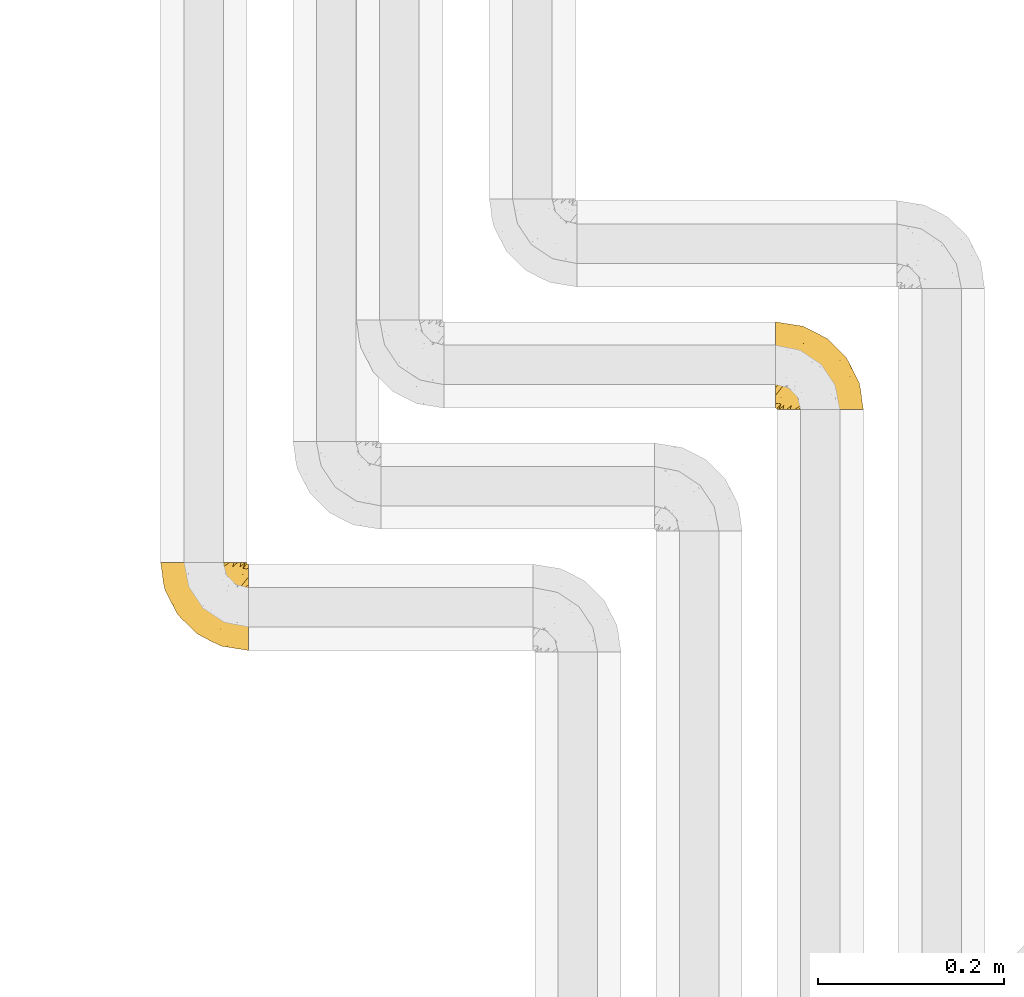
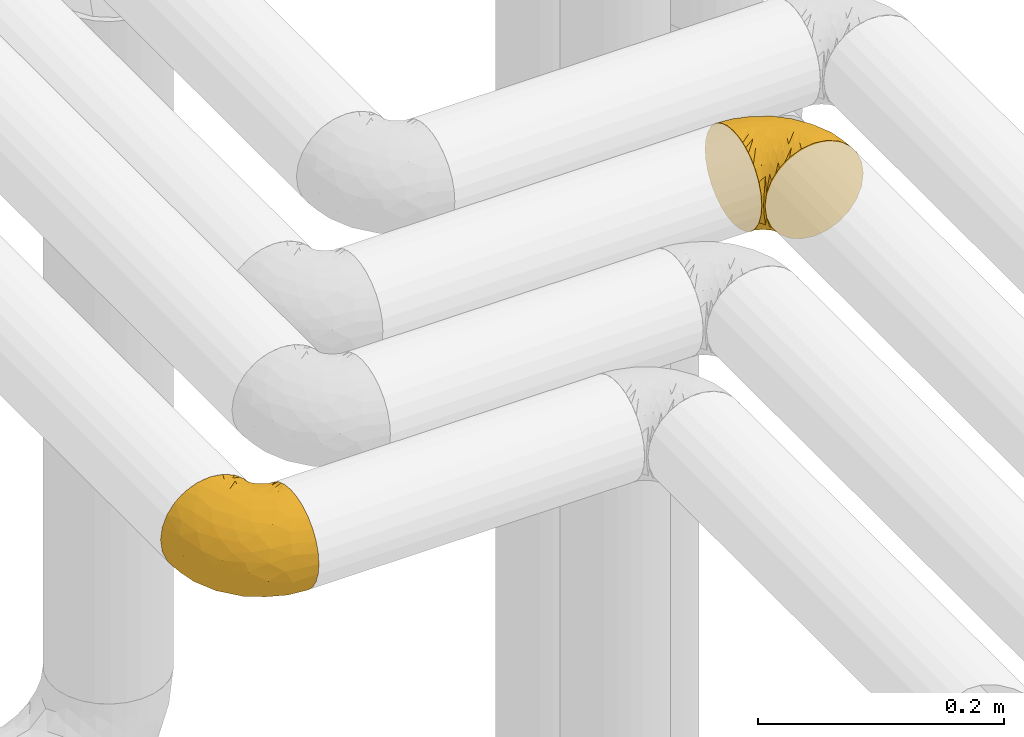
# One storey, part 260 of 827: 2 coverings.
"""IFC2X3 building model written with IfcOpenShell, lengths in millimetres."""

from ifc_helpers import new_model, entity, si_unit, converted_unit, derived_unit, direction, frame, origin, place, context, subcontext, project, spatial, faceted_brep, element, save


model = new_model("IFC2X3")

# Units and contexts
model_context = context("Model", 3, precision=0.01, world=origin(), true_north=direction((6.12303176911189e-17, 1.0)))
body_context = subcontext(model_context, "Body", "Model", "MODEL_VIEW")
ifc_project = project(units=[si_unit("LENGTHUNIT", "METRE", prefix="MILLI"), si_unit("AREAUNIT", "SQUARE_METRE"), si_unit("VOLUMEUNIT", "CUBIC_METRE"), converted_unit("PLANEANGLEUNIT", "DEGREE", entity("IfcRatioMeasure", 0.0174532925199433), si_unit("PLANEANGLEUNIT", "RADIAN"), dimensions=[0, 0, 0, 0, 0, 0, 0]), si_unit("MASSUNIT", "GRAM", prefix="KILO"), derived_unit("MASSDENSITYUNIT", [(si_unit("MASSUNIT", "GRAM", prefix="KILO"), 1), (si_unit("LENGTHUNIT", "METRE"), -3)]), derived_unit("MOMENTOFINERTIAUNIT", [(si_unit("LENGTHUNIT", "METRE"), 4)]), si_unit("TIMEUNIT", "SECOND"), si_unit("FREQUENCYUNIT", "HERTZ"), si_unit("THERMODYNAMICTEMPERATUREUNIT", "DEGREE_CELSIUS"), derived_unit("THERMALTRANSMITTANCEUNIT", [(si_unit("MASSUNIT", "GRAM", prefix="KILO"), 1), (si_unit("THERMODYNAMICTEMPERATUREUNIT", "KELVIN"), -1), (si_unit("TIMEUNIT", "SECOND"), -3)]), derived_unit("VOLUMETRICFLOWRATEUNIT", [(si_unit("LENGTHUNIT", "METRE"), 3), (si_unit("TIMEUNIT", "SECOND"), -1)]), derived_unit("MASSFLOWRATEUNIT", [(si_unit("MASSUNIT", "GRAM", prefix="KILO"), 1), (si_unit("TIMEUNIT", "SECOND"), -1)]), derived_unit("ROTATIONALFREQUENCYUNIT", [(si_unit("TIMEUNIT", "SECOND"), -1)]), si_unit("ELECTRICCURRENTUNIT", "AMPERE"), si_unit("ELECTRICVOLTAGEUNIT", "VOLT"), si_unit("POWERUNIT", "WATT"), si_unit("FORCEUNIT", "NEWTON", prefix="KILO"), si_unit("ILLUMINANCEUNIT", "LUX"), si_unit("LUMINOUSFLUXUNIT", "LUMEN"), si_unit("LUMINOUSINTENSITYUNIT", "CANDELA"), derived_unit("USERDEFINED", [(si_unit("MASSUNIT", "GRAM", prefix="KILO"), -1), (si_unit("LENGTHUNIT", "METRE"), -2), (si_unit("TIMEUNIT", "SECOND"), 3), (si_unit("LUMINOUSFLUXUNIT", "LUMEN"), 1)]), derived_unit("LINEARVELOCITYUNIT", [(si_unit("LENGTHUNIT", "METRE"), 1), (si_unit("TIMEUNIT", "SECOND"), -1)]), si_unit("PRESSUREUNIT", "PASCAL"), derived_unit("USERDEFINED", [(si_unit("LENGTHUNIT", "METRE"), -2), (si_unit("MASSUNIT", "GRAM", prefix="KILO"), 1), (si_unit("TIMEUNIT", "SECOND"), -2)]), derived_unit("LINEARFORCEUNIT", [(si_unit("MASSUNIT", "GRAM", prefix="KILO"), 1), (si_unit("LENGTHUNIT", "METRE"), 1), (si_unit("TIMEUNIT", "SECOND"), -2), (si_unit("LENGTHUNIT", "METRE"), -1)]), derived_unit("PLANARFORCEUNIT", [(si_unit("MASSUNIT", "GRAM", prefix="KILO"), 1), (si_unit("LENGTHUNIT", "METRE"), 1), (si_unit("TIMEUNIT", "SECOND"), -2), (si_unit("LENGTHUNIT", "METRE"), -2)])], contexts=[model_context])

# Site, building, storey
site_placement = place(None, origin())
site = spatial("IfcSite", under=ifc_project, at=site_placement, CompositionType="ELEMENT")
building_placement = place(site_placement, origin())
building = spatial("IfcBuilding", under=site, at=building_placement, CompositionType="ELEMENT")
storey_placement = place(building_placement, frame((0.0, 0.0, 28200.0)))
storey = spatial("IfcBuildingStorey", under=building, at=storey_placement, Name="08", CompositionType="ELEMENT", Elevation=28200.0)

# Coverings
covering_1_placement = place(storey_placement, frame((31126.93, 17201.61, 2952.2)))
element("IfcCovering", 1, at=covering_1_placement, inside=storey, Name=":ADSK_", ObjectType=":ADSK_", PredefinedType="INSULATION", context=body_context, shape_type="Brep", body=[
    faceted_brep([(1.6, 59.88, 92.84), (1.6, 69.65, 89.42), (1.6, 78.41, 83.91), (1.6, 85.72, 76.59), (1.6, 91.22, 67.83), (1.6, 94.64, 58.07), (1.6, 95.8, 47.8), (1.6, 94.64, 37.51), (1.6, 91.22, 27.74), (1.6, 85.71, 18.98), (1.6, 78.39, 11.67), (1.6, 69.63, 6.17), (1.6, 59.87, 2.75), (1.6, 49.6, 1.6), (1.6, 45.45, 2.06), (1.6, 42.38, 2.41), (1.6, 39.31, 2.75), (1.6, 34.43, 4.46), (1.6, 29.54, 6.17), (1.6, 25.16, 8.93), (1.6, 20.78, 11.68), (1.6, 17.13, 15.34), (1.6, 13.47, 19.0), (1.6, 7.97, 27.76), (1.6, 6.26, 32.64), (1.6, 4.55, 37.52), (1.6, 3.4, 47.8), (1.6, 4.55, 58.08), (1.6, 6.26, 62.96), (1.6, 7.97, 67.85), (1.6, 13.48, 76.61), (1.6, 17.14, 80.26), (1.6, 20.8, 83.92), (1.6, 25.18, 86.67), (1.6, 29.56, 89.42), (1.6, 34.44, 91.13), (1.6, 39.32, 92.84), (1.6, 42.39, 93.18), (1.6, 45.45, 93.53), (1.6, 49.6, 94.0), (3.4, 1.6, 47.8), (4.97, 1.6, 35.84), (9.58, 1.6, 24.7), (13.26, 1.6, 19.91), (16.93, 1.6, 15.13), (21.71, 1.6, 11.46), (26.5, 1.6, 7.78), (32.07, 1.6, 5.48), (37.64, 1.6, 3.17), (41.25, 1.6, 2.69), (43.34, 1.6, 2.42), (45.42, 1.6, 2.14), (49.6, 1.6, 1.6), (61.55, 1.6, 3.17), (72.7, 1.6, 7.78), (82.26, 1.6, 15.13), (89.61, 1.6, 24.7), (94.22, 1.6, 35.84), (95.8, 1.6, 47.8), (94.22, 1.6, 59.75), (89.61, 1.6, 70.9), (82.26, 1.6, 80.46), (72.7, 1.6, 87.81), (61.55, 1.6, 92.42), (49.6, 1.6, 94.0), (45.42, 1.6, 93.45), (41.25, 1.6, 92.9), (37.64, 1.6, 92.42), (32.07, 1.6, 90.11), (26.5, 1.6, 87.81), (21.71, 1.6, 84.13), (16.93, 1.6, 80.46), (13.26, 1.6, 75.68), (9.58, 1.6, 70.9), (4.97, 1.6, 59.75), (81.55, 36.81, 71.98), (90.4, 23.28, 63.6), (83.0, 45.8, 59.72), (91.18, 30.7, 47.8), (93.13, 21.2, 55.16), (94.0, 12.96, 47.8), (66.19, 66.19, 63.76), (70.92, 54.51, 72.22), (85.95, 17.98, 74.18), (49.74, 36.69, 92.52), (35.54, 35.54, 94.0), (38.14, 31.64, 94.0), (40.74, 27.75, 94.0), (43.34, 23.86, 94.0), (45.94, 19.96, 94.0), (77.59, 22.8, 82.14), (71.17, 42.67, 80.34), (65.81, 33.21, 87.52), (59.03, 59.45, 79.59), (45.85, 71.5, 78.25), (45.79, 62.66, 85.01), (41.42, 54.5, 90.25), (34.51, 47.57, 93.2), (56.04, 48.81, 87.23), (15.15, 74.98, 85.55), (56.51, 18.7, 93.0), (68.39, 15.75, 89.31), (23.33, 91.17, 61.31), (42.86, 85.28, 56.86), (39.42, 82.58, 68.34), (53.58, 75.78, 65.71), (59.17, 74.98, 56.99), (59.06, 67.27, 72.15), (22.63, 87.38, 70.34), (20.55, 82.04, 78.36), (12.96, 94.0, 47.8), (56.96, 77.8, 47.8), (67.38, 67.38, 47.8), (18.72, 56.2, 93.06), (5.33, 48.85, 94.0), (9.07, 48.11, 94.0), (11.79, 47.57, 94.0), (14.51, 47.03, 94.0), (17.24, 46.48, 94.0), (19.96, 45.94, 94.0), (21.03, 65.78, 89.88), (46.48, 17.24, 94.0), (47.03, 14.51, 94.0), (47.57, 11.79, 94.0), (48.11, 9.07, 94.0), (48.48, 7.2, 94.0), (48.85, 5.33, 94.0), (30.7, 91.18, 47.8), (23.86, 43.34, 94.0), (27.75, 40.74, 94.0), (31.64, 38.14, 94.0), (31.26, 72.73, 83.7), (77.8, 56.96, 47.8), (72.75, 62.23, 55.9), (43.83, 84.49, 47.8), (84.49, 43.83, 47.8), (14.58, 12.05, 81.75), (16.17, 18.95, 86.43), (10.82, 13.02, 79.8), (4.64, 8.34, 69.84), (7.71, 14.63, 79.5), (25.13, 11.09, 88.08), (32.66, 13.66, 91.6), (34.94, 20.08, 92.93), (36.76, 9.61, 92.43), (40.48, 9.48, 93.24), (39.25, 16.1, 93.36), (3.69, 3.42, 57.25), (13.99, 26.63, 89.41), (21.85, 33.72, 92.89), (17.93, 34.77, 92.66), (15.11, 6.75, 79.58), (21.14, 13.31, 86.51), (7.21, 19.94, 83.91), (9.47, 27.05, 88.76), (32.27, 8.67, 90.94), (25.68, 26.11, 91.94), (22.18, 29.3, 91.98), (18.79, 6.32, 82.79), (10.12, 39.92, 93.16), (10.45, 6.04, 73.94), (11.29, 34.4, 91.89), (2.87, 2.87, 47.8), (31.16, 20.92, 92.22), (12.7, 21.11, 86.29), (6.31, 27.43, 88.56), (25.62, 7.54, 87.72), (21.18, 18.45, 88.33), (28.81, 23.88, 92.18), (7.45, 7.77, 71.78), (21.14, 13.3, 9.09), (25.13, 11.09, 7.51), (18.79, 6.33, 12.8), (48.11, 9.07, 1.6), (48.85, 5.33, 1.6), (47.03, 14.51, 1.6), (47.57, 11.79, 1.6), (3.69, 3.42, 38.35), (7.44, 7.76, 23.84), (14.51, 47.03, 1.6), (11.79, 47.57, 1.6), (5.33, 48.85, 1.6), (9.07, 48.11, 1.6), (7.71, 14.62, 16.1), (9.47, 27.03, 6.84), (34.94, 20.08, 2.66), (31.16, 20.92, 3.37), (40.74, 27.75, 1.6), (38.14, 31.64, 1.6), (36.76, 9.61, 3.16), (40.48, 9.48, 2.35), (4.63, 8.33, 25.77), (15.11, 6.74, 16.02), (14.58, 12.04, 13.85), (43.34, 23.86, 1.6), (45.94, 19.96, 1.6), (39.25, 16.1, 2.23), (7.21, 19.93, 11.69), (12.69, 21.1, 9.31), (10.14, 39.92, 2.43), (21.81, 33.68, 2.71), (22.19, 29.28, 3.61), (14.0, 26.62, 6.18), (25.69, 26.08, 3.66), (16.17, 18.93, 9.17), (6.66, 27.87, 6.77), (17.92, 34.75, 2.93), (10.45, 6.04, 21.66), (31.64, 38.14, 1.6), (10.64, 12.79, 16.09), (11.31, 34.41, 3.7), (19.96, 45.94, 1.6), (23.86, 43.34, 1.6), (27.75, 40.74, 1.6), (32.66, 13.66, 3.99), (46.48, 17.24, 1.6), (32.27, 8.67, 4.65), (35.54, 35.54, 1.6), (28.77, 23.83, 3.43), (21.17, 18.43, 7.27), (23.36, 6.03, 9.46), (17.24, 46.48, 1.6), (47.58, 34.52, 2.4), (93.13, 21.2, 40.43), (77.44, 23.82, 13.57), (66.78, 41.32, 11.3), (71.68, 47.62, 18.65), (74.96, 52.66, 27.26), (81.55, 36.81, 23.61), (36.7, 49.75, 3.07), (56.9, 19.07, 2.69), (83.0, 45.8, 35.87), (90.4, 23.28, 31.99), (67.83, 21.35, 6.71), (85.95, 17.98, 21.41), (39.41, 82.57, 27.24), (23.33, 91.17, 34.26), (42.87, 85.27, 38.73), (53.92, 73.89, 26.97), (66.19, 66.19, 31.83), (64.12, 62.43, 23.4), (33.13, 63.53, 6.91), (23.1, 58.45, 3.4), (16.98, 67.16, 5.84), (72.75, 62.22, 39.69), (23.77, 81.54, 17.6), (18.41, 74.8, 10.38), (43.7, 75.83, 20.6), (54.53, 41.45, 5.36), (55.72, 76.72, 35.73), (17.73, 88.2, 24.84), (38.98, 71.6, 13.87), (50.28, 56.23, 9.06), (59.02, 59.44, 15.99)], [[[0, 1, 2, 3, 4, 5, 6, 7, 8, 9, 10, 11, 12, 13, 14, 15, 16, 17, 18, 19, 20, 21, 22, 23, 24, 25, 26, 27, 28, 29, 30, 31, 32, 33, 34, 35, 36, 37, 38, 39]], [[40, 41, 42, 43, 44, 45, 46, 47, 48, 49, 50, 51, 52, 53, 54, 55, 56, 57, 58, 59, 60, 61, 62, 63, 64, 65, 66, 67, 68, 69, 70, 71, 72, 73, 74]], [[75, 76, 77]], [[78, 79, 80]], [[77, 81, 82]], [[76, 75, 83]], [[84, 85, 86, 87, 88, 89]], [[90, 91, 92]], [[76, 60, 59]], [[93, 94, 95]], [[90, 62, 61]], [[83, 61, 60]], [[96, 97, 84]], [[98, 93, 95]], [[2, 1, 99]], [[100, 84, 89]], [[62, 101, 63]], [[4, 102, 5]], [[92, 84, 100]], [[103, 102, 104]], [[103, 105, 106]], [[93, 107, 94]], [[3, 108, 4]], [[92, 101, 90]], [[108, 3, 109]], [[102, 110, 5]], [[93, 82, 107]], [[102, 108, 104]], [[111, 106, 112]], [[109, 2, 99]], [[113, 39, 114, 115, 116, 117, 118, 119]], [[120, 0, 113]], [[100, 89, 121, 122, 123, 124, 125, 126, 64]], [[127, 102, 103]], [[97, 119, 128, 129, 130, 85]], [[99, 120, 131]], [[132, 133, 77]], [[59, 80, 79]], [[3, 2, 109]], [[98, 84, 92]], [[94, 109, 131]], [[120, 1, 0]], [[93, 91, 82]], [[104, 94, 105]], [[97, 113, 119]], [[95, 120, 96]], [[83, 90, 61]], [[91, 93, 98]], [[64, 63, 100]], [[100, 63, 101]], [[77, 76, 79]], [[133, 106, 81]], [[84, 97, 85]], [[113, 96, 120]], [[113, 97, 96]], [[39, 113, 0]], [[110, 102, 127]], [[110, 6, 5]], [[103, 111, 134, 127]], [[90, 75, 91]], [[82, 81, 107]], [[91, 75, 82]], [[77, 82, 75]], [[76, 83, 60]], [[90, 83, 75]], [[105, 107, 81]], [[94, 131, 95]], [[105, 94, 107]], [[109, 94, 104]], [[120, 95, 131]], [[98, 95, 96]], [[84, 98, 96]], [[98, 92, 91]], [[106, 105, 81]], [[103, 104, 105]], [[112, 106, 133]], [[103, 106, 111]], [[112, 133, 132]], [[81, 77, 133]], [[77, 78, 135, 132]], [[120, 99, 1]], [[109, 99, 131]], [[59, 58, 80]], [[59, 79, 76]], [[90, 101, 62]], [[100, 101, 92]], [[4, 108, 102]], [[109, 104, 108]], [[78, 77, 79]], [[136, 137, 138]], [[29, 139, 140]], [[141, 142, 143]], [[144, 145, 121]], [[146, 89, 88]], [[147, 139, 27]], [[148, 149, 150]], [[136, 151, 152]], [[147, 40, 74]], [[26, 147, 27]], [[153, 148, 154]], [[35, 116, 36]], [[73, 72, 151]], [[114, 39, 38, 37, 36, 116, 115]], [[146, 155, 144]], [[156, 85, 130]], [[157, 149, 148]], [[151, 158, 152]], [[117, 35, 159]], [[31, 153, 154]], [[160, 74, 73]], [[161, 128, 119]], [[65, 64, 126, 125, 124, 123, 122, 67, 66]], [[162, 147, 26]], [[29, 140, 30]], [[149, 129, 150]], [[139, 29, 28, 27]], [[68, 144, 69]], [[129, 128, 150]], [[163, 87, 86]], [[130, 129, 149]], [[122, 145, 67]], [[153, 164, 148]], [[161, 119, 159]], [[165, 32, 154]], [[150, 154, 148]], [[128, 161, 150]], [[32, 165, 33]], [[145, 144, 68]], [[89, 146, 144]], [[87, 163, 143]], [[166, 155, 142]], [[88, 87, 143]], [[161, 154, 150]], [[154, 32, 31]], [[31, 30, 153]], [[30, 140, 153]], [[164, 153, 140]], [[140, 137, 164]], [[157, 148, 164]], [[156, 130, 157]], [[164, 137, 157]], [[157, 137, 156]], [[167, 137, 136]], [[168, 85, 156]], [[152, 168, 167]], [[167, 168, 156]], [[163, 152, 141]], [[71, 158, 72]], [[152, 167, 136]], [[88, 142, 146]], [[144, 155, 69]], [[146, 142, 155]], [[70, 166, 71]], [[142, 141, 166]], [[70, 69, 155]], [[141, 158, 71]], [[160, 73, 151]], [[138, 137, 140]], [[160, 136, 169]], [[136, 160, 151]], [[74, 160, 169]], [[152, 158, 141]], [[151, 72, 158]], [[168, 152, 163]], [[137, 167, 156]], [[163, 86, 168]], [[85, 168, 86]], [[116, 35, 117]], [[130, 149, 157]], [[67, 145, 68]], [[121, 89, 144]], [[145, 122, 121]], [[40, 147, 162]], [[169, 147, 74]], [[159, 35, 34]], [[161, 159, 34]], [[159, 119, 118, 117]], [[139, 147, 169]], [[139, 169, 138]], [[161, 34, 33]], [[141, 143, 163]], [[88, 143, 142]], [[71, 166, 141]], [[155, 166, 70]], [[139, 138, 140]], [[169, 136, 138]], [[154, 161, 165]], [[161, 33, 165]], [[170, 171, 172]], [[173, 174, 52, 51, 50, 49, 48, 175, 176]], [[177, 178, 41]], [[179, 17, 180]], [[14, 13, 181, 182, 180, 16, 15]], [[183, 23, 22]], [[21, 20, 184]], [[185, 186, 187]], [[186, 188, 187]], [[43, 172, 44]], [[189, 190, 47]], [[25, 24, 23, 191]], [[170, 192, 193]], [[40, 162, 177]], [[194, 195, 196]], [[26, 25, 177]], [[197, 198, 183]], [[199, 17, 179]], [[178, 177, 191]], [[47, 46, 189]], [[200, 201, 202]], [[201, 203, 204]], [[205, 206, 184]], [[207, 41, 178]], [[18, 17, 199]], [[16, 180, 17]], [[202, 201, 198]], [[208, 201, 200]], [[162, 26, 177]], [[48, 47, 190]], [[196, 195, 189]], [[197, 184, 202]], [[204, 193, 209]], [[210, 211, 212]], [[206, 212, 213]], [[205, 19, 210]], [[184, 206, 202]], [[210, 212, 206]], [[185, 194, 214]], [[189, 215, 190]], [[216, 45, 214]], [[186, 171, 170]], [[189, 216, 196]], [[197, 22, 21]], [[194, 185, 187]], [[197, 183, 22]], [[184, 197, 21]], [[197, 202, 198]], [[206, 200, 202]], [[204, 183, 198]], [[201, 208, 203]], [[203, 208, 217]], [[204, 198, 201]], [[217, 188, 218]], [[193, 219, 170]], [[171, 186, 185]], [[170, 218, 186]], [[170, 219, 218]], [[42, 207, 192]], [[171, 220, 172]], [[216, 189, 46]], [[214, 194, 196]], [[44, 220, 45]], [[214, 196, 216]], [[216, 46, 45]], [[214, 45, 220]], [[192, 43, 42]], [[204, 203, 219]], [[207, 193, 192]], [[209, 193, 178]], [[41, 207, 42]], [[193, 207, 178]], [[43, 192, 172]], [[170, 172, 192]], [[204, 219, 193]], [[219, 203, 218]], [[217, 218, 203]], [[188, 186, 218]], [[206, 213, 200]], [[208, 200, 213]], [[199, 210, 18]], [[215, 189, 195]], [[215, 175, 190]], [[175, 48, 190]], [[199, 179, 221, 211]], [[210, 199, 211]], [[25, 191, 177]], [[40, 177, 41]], [[191, 183, 209]], [[23, 183, 191]], [[205, 20, 19]], [[19, 18, 210]], [[171, 185, 214]], [[172, 220, 44]], [[214, 220, 171]], [[191, 209, 178]], [[204, 209, 183]], [[206, 205, 210]], [[20, 205, 184]], [[222, 195, 194, 187, 188, 217]], [[57, 223, 80]], [[224, 225, 226]], [[226, 227, 228]], [[229, 217, 208, 213, 212, 211]], [[230, 52, 174, 173, 176, 175, 215, 195]], [[231, 232, 228]], [[231, 78, 223]], [[223, 57, 232]], [[224, 233, 225]], [[233, 54, 53]], [[234, 232, 56]], [[56, 55, 234]], [[234, 224, 228]], [[235, 236, 237]], [[224, 55, 54]], [[238, 239, 240]], [[52, 230, 53]], [[241, 242, 243]], [[231, 227, 244]], [[13, 12, 242]], [[236, 8, 7]], [[9, 245, 10]], [[10, 246, 11]], [[238, 247, 235]], [[222, 229, 248]], [[242, 211, 221, 179, 180, 182, 181, 13]], [[233, 53, 230]], [[111, 112, 249]], [[250, 8, 236]], [[246, 251, 241]], [[8, 250, 9]], [[127, 236, 110]], [[248, 229, 252]], [[246, 10, 245]], [[235, 245, 250]], [[236, 7, 110]], [[235, 249, 238]], [[237, 236, 127]], [[243, 11, 246]], [[252, 229, 241]], [[56, 232, 57]], [[222, 230, 195]], [[225, 248, 252]], [[248, 233, 230]], [[54, 233, 224]], [[231, 228, 227]], [[244, 132, 231]], [[248, 225, 233]], [[226, 225, 253]], [[235, 250, 236]], [[245, 9, 250]], [[251, 246, 245]], [[243, 246, 241]], [[247, 245, 235]], [[252, 251, 253]], [[229, 222, 217]], [[230, 222, 248]], [[7, 6, 110]], [[237, 127, 134, 111]], [[238, 249, 239]], [[224, 234, 55]], [[232, 234, 228]], [[242, 241, 229]], [[12, 11, 243]], [[211, 242, 229]], [[12, 243, 242]], [[80, 223, 78]], [[80, 58, 57]], [[231, 223, 232]], [[227, 240, 239]], [[224, 226, 228]], [[240, 226, 253]], [[227, 239, 244]], [[226, 240, 227]], [[251, 247, 253]], [[240, 253, 247]], [[249, 235, 237]], [[237, 111, 249]], [[244, 239, 249]], [[112, 244, 249]], [[135, 78, 231, 132]], [[112, 132, 244]], [[247, 238, 240]], [[245, 247, 251]], [[251, 252, 241]], [[225, 252, 253]]]),
])
covering_2_placement = place(storey_placement, frame((30467.25, 16943.41, 2952.2)))
element("IfcCovering", 2, at=covering_2_placement, inside=storey, Name=":ADSK_", ObjectType=":ADSK_", PredefinedType="INSULATION", context=body_context, shape_type="Brep", body=[
    faceted_brep([(95.8, 37.51, 92.84), (95.8, 27.74, 89.42), (95.8, 18.98, 83.91), (95.8, 11.67, 76.59), (95.8, 6.17, 67.83), (95.8, 2.75, 58.07), (95.8, 1.6, 47.8), (95.8, 2.75, 37.51), (95.8, 6.17, 27.74), (95.8, 11.68, 18.98), (95.8, 19.0, 11.67), (95.8, 27.76, 6.17), (95.8, 37.52, 2.75), (95.8, 47.8, 1.6), (95.8, 51.94, 2.06), (95.8, 55.01, 2.41), (95.8, 58.08, 2.75), (95.8, 62.96, 4.46), (95.8, 67.85, 6.17), (95.8, 72.23, 8.93), (95.8, 76.61, 11.68), (95.8, 80.26, 15.34), (95.8, 83.92, 19.0), (95.8, 89.42, 27.76), (95.8, 91.13, 32.64), (95.8, 92.84, 37.52), (95.8, 94.0, 47.8), (95.8, 92.84, 58.08), (95.8, 91.13, 62.96), (95.8, 89.42, 67.85), (95.8, 83.91, 76.61), (95.8, 80.25, 80.26), (95.8, 76.59, 83.92), (95.8, 72.21, 86.67), (95.8, 67.83, 89.42), (95.8, 62.95, 91.13), (95.8, 58.07, 92.84), (95.8, 55.0, 93.18), (95.8, 51.94, 93.53), (95.8, 47.8, 94.0), (94.0, 95.8, 47.8), (92.42, 95.8, 35.84), (87.81, 95.8, 24.7), (84.13, 95.8, 19.91), (80.46, 95.8, 15.13), (75.68, 95.8, 11.46), (70.9, 95.8, 7.78), (65.32, 95.8, 5.48), (59.75, 95.8, 3.17), (56.14, 95.8, 2.69), (54.06, 95.8, 2.42), (51.97, 95.8, 2.14), (47.8, 95.8, 1.6), (35.84, 95.8, 3.17), (24.7, 95.8, 7.78), (15.13, 95.8, 15.13), (7.78, 95.8, 24.7), (3.17, 95.8, 35.84), (1.6, 95.8, 47.8), (3.17, 95.8, 59.75), (7.78, 95.8, 70.9), (15.13, 95.8, 80.46), (24.7, 95.8, 87.81), (35.84, 95.8, 92.42), (47.8, 95.8, 94.0), (51.97, 95.8, 93.45), (56.14, 95.8, 92.9), (59.75, 95.8, 92.42), (65.32, 95.8, 90.11), (70.9, 95.8, 87.81), (75.68, 95.8, 84.13), (80.46, 95.8, 80.46), (84.13, 95.8, 75.68), (87.81, 95.8, 70.9), (92.42, 95.8, 59.75), (15.84, 60.58, 71.98), (6.99, 74.11, 63.6), (14.39, 51.59, 59.72), (6.21, 66.69, 47.8), (4.26, 76.19, 55.16), (3.39, 84.43, 47.8), (31.2, 31.2, 63.76), (26.47, 42.88, 72.22), (11.44, 79.41, 74.18), (47.66, 60.7, 92.52), (61.85, 61.85, 94.0), (59.25, 65.75, 94.0), (56.65, 69.64, 94.0), (54.05, 73.53, 94.0), (51.45, 77.43, 94.0), (19.8, 74.59, 82.14), (26.22, 54.72, 80.34), (31.58, 64.18, 87.52), (38.36, 37.94, 79.59), (51.54, 25.89, 78.25), (51.6, 34.73, 85.01), (55.97, 42.89, 90.25), (62.88, 49.83, 93.2), (41.35, 48.58, 87.23), (82.24, 22.41, 85.55), (40.88, 78.69, 93.0), (29.0, 81.64, 89.31), (74.06, 6.22, 61.31), (54.53, 12.11, 56.86), (57.98, 14.81, 68.34), (43.81, 21.61, 65.71), (38.22, 22.41, 56.99), (38.33, 30.12, 72.15), (74.76, 10.01, 70.34), (76.85, 15.36, 78.36), (84.43, 3.39, 47.8), (40.43, 19.59, 47.8), (30.01, 30.01, 47.8), (78.67, 41.19, 93.06), (92.06, 48.54, 94.0), (88.32, 49.28, 94.0), (85.6, 49.82, 94.0), (82.88, 50.37, 94.0), (80.15, 50.91, 94.0), (77.43, 51.45, 94.0), (76.36, 31.61, 89.88), (50.91, 80.15, 94.0), (50.37, 82.88, 94.0), (49.82, 85.6, 94.0), (49.28, 88.32, 94.0), (48.91, 90.19, 94.0), (48.54, 92.06, 94.0), (66.69, 6.21, 47.8), (73.53, 54.05, 94.0), (69.64, 56.65, 94.0), (65.75, 59.25, 94.0), (66.13, 24.66, 83.7), (19.59, 40.43, 47.8), (24.64, 35.17, 55.9), (53.56, 12.9, 47.8), (12.9, 53.56, 47.8), (82.81, 85.34, 81.75), (81.22, 78.44, 86.43), (86.57, 84.37, 79.8), (92.75, 89.05, 69.84), (89.68, 82.76, 79.5), (72.26, 86.31, 88.08), (64.73, 83.73, 91.6), (62.45, 77.31, 92.93), (60.63, 87.78, 92.43), (56.91, 87.91, 93.24), (58.14, 81.29, 93.36), (93.7, 93.97, 57.25), (83.4, 70.76, 89.41), (75.54, 63.67, 92.89), (79.46, 62.62, 92.66), (82.28, 90.64, 79.58), (76.25, 84.08, 86.51), (84.69, 76.28, 86.29), (90.18, 77.45, 83.91), (86.94, 91.35, 73.94), (65.12, 88.72, 90.94), (71.71, 71.28, 91.94), (75.21, 68.09, 91.98), (78.6, 91.07, 82.79), (87.27, 57.47, 93.16), (87.92, 70.34, 88.76), (86.1, 62.99, 91.89), (94.52, 94.52, 47.8), (66.23, 76.47, 92.22), (91.08, 69.96, 88.56), (71.77, 89.86, 87.72), (76.21, 78.94, 88.33), (68.59, 73.51, 92.18), (89.94, 89.62, 71.78), (76.22, 78.96, 7.27), (81.22, 78.46, 9.17), (71.7, 71.31, 3.66), (49.28, 88.32, 1.6), (48.54, 92.06, 1.6), (50.37, 82.88, 1.6), (49.82, 85.6, 1.6), (93.7, 93.97, 38.35), (89.95, 89.63, 23.84), (82.88, 50.37, 1.6), (85.6, 49.82, 1.6), (92.06, 48.54, 1.6), (88.32, 49.28, 1.6), (89.68, 82.77, 16.1), (87.92, 70.36, 6.84), (62.45, 77.31, 2.66), (66.24, 76.47, 3.37), (56.65, 69.64, 1.6), (59.25, 65.75, 1.6), (78.6, 91.06, 12.8), (60.63, 87.78, 3.16), (56.91, 87.91, 2.35), (92.76, 89.06, 25.77), (76.25, 84.09, 9.09), (82.28, 90.65, 16.02), (82.81, 85.35, 13.85), (54.05, 73.53, 1.6), (51.45, 77.43, 1.6), (58.14, 81.29, 2.23), (90.18, 77.46, 11.69), (84.7, 76.29, 9.31), (87.25, 57.47, 2.43), (75.58, 63.71, 2.71), (75.2, 68.11, 3.61), (83.39, 70.77, 6.18), (90.73, 69.52, 6.77), (79.47, 62.64, 2.93), (86.94, 91.35, 21.66), (65.75, 59.25, 1.6), (86.75, 84.6, 16.09), (86.08, 62.98, 3.7), (77.43, 51.45, 1.6), (73.53, 54.05, 1.6), (69.64, 56.65, 1.6), (64.73, 83.73, 3.99), (50.91, 80.15, 1.6), (65.12, 88.72, 4.65), (72.26, 86.3, 7.51), (61.85, 61.85, 1.6), (68.62, 73.56, 3.43), (74.03, 91.36, 9.46), (80.15, 50.91, 1.6), (49.81, 62.87, 2.4), (4.26, 76.19, 40.43), (19.95, 73.57, 13.57), (30.61, 56.07, 11.3), (25.71, 49.77, 18.65), (22.43, 44.73, 27.26), (15.85, 60.58, 23.61), (60.69, 47.64, 3.07), (40.49, 78.32, 2.69), (14.39, 51.59, 35.87), (6.99, 74.11, 31.99), (29.56, 76.04, 6.71), (11.45, 79.41, 21.41), (57.98, 14.82, 27.24), (74.06, 6.22, 34.26), (54.52, 12.12, 38.73), (43.47, 23.51, 26.97), (31.2, 31.2, 31.83), (33.27, 34.96, 23.4), (64.26, 33.86, 6.91), (74.29, 38.94, 3.4), (80.41, 30.23, 5.84), (41.67, 20.67, 35.73), (24.64, 35.17, 39.69), (73.62, 15.85, 17.6), (78.98, 22.59, 10.38), (53.69, 21.56, 20.6), (42.86, 55.94, 5.36), (79.66, 9.19, 24.84), (58.41, 25.79, 13.87), (47.11, 41.16, 9.06), (38.37, 37.95, 15.99)], [[[0, 1, 2, 3, 4, 5, 6, 7, 8, 9, 10, 11, 12, 13, 14, 15, 16, 17, 18, 19, 20, 21, 22, 23, 24, 25, 26, 27, 28, 29, 30, 31, 32, 33, 34, 35, 36, 37, 38, 39]], [[40, 41, 42, 43, 44, 45, 46, 47, 48, 49, 50, 51, 52, 53, 54, 55, 56, 57, 58, 59, 60, 61, 62, 63, 64, 65, 66, 67, 68, 69, 70, 71, 72, 73, 74]], [[75, 76, 77]], [[78, 79, 80]], [[77, 81, 82]], [[76, 75, 83]], [[84, 85, 86, 87, 88, 89]], [[90, 91, 92]], [[76, 60, 59]], [[93, 94, 95]], [[90, 62, 61]], [[83, 61, 60]], [[96, 97, 84]], [[98, 93, 95]], [[2, 1, 99]], [[100, 84, 89]], [[62, 101, 63]], [[4, 102, 5]], [[92, 84, 100]], [[103, 102, 104]], [[103, 105, 106]], [[93, 107, 94]], [[3, 108, 4]], [[92, 101, 90]], [[108, 3, 109]], [[102, 110, 5]], [[93, 82, 107]], [[102, 108, 104]], [[111, 106, 112]], [[109, 2, 99]], [[113, 39, 114, 115, 116, 117, 118, 119]], [[120, 0, 113]], [[100, 89, 121, 122, 123, 124, 125, 126, 64]], [[127, 102, 103]], [[97, 119, 128, 129, 130, 85]], [[99, 120, 131]], [[132, 133, 77]], [[59, 80, 79]], [[3, 2, 109]], [[98, 84, 92]], [[94, 109, 131]], [[120, 1, 0]], [[93, 91, 82]], [[104, 94, 105]], [[97, 113, 119]], [[95, 120, 96]], [[83, 90, 61]], [[91, 93, 98]], [[64, 63, 100]], [[100, 63, 101]], [[77, 76, 79]], [[133, 106, 81]], [[84, 97, 85]], [[113, 96, 120]], [[113, 97, 96]], [[39, 113, 0]], [[110, 102, 127]], [[110, 6, 5]], [[103, 111, 134, 127]], [[90, 75, 91]], [[82, 81, 107]], [[91, 75, 82]], [[77, 82, 75]], [[76, 83, 60]], [[90, 83, 75]], [[105, 107, 81]], [[94, 131, 95]], [[105, 94, 107]], [[109, 94, 104]], [[120, 95, 131]], [[98, 95, 96]], [[84, 98, 96]], [[98, 92, 91]], [[106, 105, 81]], [[103, 104, 105]], [[112, 106, 133]], [[103, 106, 111]], [[112, 133, 132]], [[81, 77, 133]], [[77, 78, 135, 132]], [[120, 99, 1]], [[109, 99, 131]], [[59, 58, 80]], [[59, 79, 76]], [[90, 101, 62]], [[100, 101, 92]], [[4, 108, 102]], [[109, 104, 108]], [[78, 77, 79]], [[136, 137, 138]], [[29, 139, 140]], [[141, 142, 143]], [[144, 145, 121]], [[146, 89, 88]], [[147, 139, 27]], [[148, 149, 150]], [[136, 151, 152]], [[147, 40, 74]], [[26, 147, 27]], [[140, 153, 154]], [[35, 116, 36]], [[73, 151, 155]], [[114, 39, 38, 37, 36, 116, 115]], [[146, 156, 144]], [[157, 85, 130]], [[158, 149, 148]], [[151, 159, 152]], [[117, 35, 160]], [[31, 154, 161]], [[155, 74, 73]], [[162, 128, 119]], [[65, 64, 126, 125, 124, 123, 122, 67, 66]], [[163, 147, 26]], [[29, 140, 30]], [[149, 129, 150]], [[139, 29, 28, 27]], [[68, 144, 69]], [[129, 128, 150]], [[164, 87, 86]], [[130, 129, 149]], [[122, 145, 67]], [[154, 153, 148]], [[162, 119, 160]], [[165, 32, 161]], [[150, 161, 148]], [[128, 162, 150]], [[32, 165, 33]], [[145, 144, 68]], [[89, 146, 144]], [[87, 164, 143]], [[166, 156, 142]], [[88, 87, 143]], [[162, 161, 150]], [[161, 32, 31]], [[154, 31, 30]], [[140, 154, 30]], [[161, 154, 148]], [[140, 137, 153]], [[158, 148, 153]], [[157, 130, 158]], [[153, 137, 158]], [[158, 137, 157]], [[167, 137, 136]], [[168, 85, 157]], [[152, 168, 167]], [[167, 168, 157]], [[164, 152, 141]], [[151, 73, 72]], [[159, 72, 71]], [[88, 142, 146]], [[144, 156, 69]], [[146, 142, 156]], [[70, 166, 71]], [[142, 141, 166]], [[70, 69, 156]], [[141, 159, 71]], [[167, 136, 152]], [[138, 137, 140]], [[155, 136, 169]], [[136, 155, 151]], [[74, 155, 169]], [[152, 159, 141]], [[151, 72, 159]], [[168, 152, 164]], [[137, 167, 157]], [[164, 86, 168]], [[85, 168, 86]], [[116, 35, 117]], [[130, 149, 158]], [[67, 145, 68]], [[121, 89, 144]], [[145, 122, 121]], [[40, 147, 163]], [[169, 147, 74]], [[160, 35, 34]], [[162, 160, 34]], [[160, 119, 118, 117]], [[139, 147, 169]], [[139, 169, 138]], [[162, 34, 33]], [[141, 143, 164]], [[88, 143, 142]], [[71, 166, 141]], [[156, 166, 70]], [[139, 138, 140]], [[169, 136, 138]], [[161, 162, 165]], [[162, 33, 165]], [[170, 171, 172]], [[173, 174, 52, 51, 50, 49, 48, 175, 176]], [[177, 178, 41]], [[179, 17, 180]], [[14, 13, 181, 182, 180, 16, 15]], [[183, 23, 22]], [[21, 20, 184]], [[185, 186, 187]], [[186, 188, 187]], [[43, 189, 44]], [[190, 191, 47]], [[25, 24, 23, 192]], [[193, 194, 195]], [[40, 163, 177]], [[196, 197, 198]], [[26, 25, 177]], [[199, 200, 183]], [[201, 17, 179]], [[47, 46, 190]], [[202, 203, 204]], [[203, 172, 171]], [[205, 206, 184]], [[207, 41, 178]], [[18, 17, 201]], [[16, 180, 17]], [[204, 203, 200]], [[208, 203, 202]], [[163, 26, 177]], [[48, 47, 191]], [[198, 197, 190]], [[199, 184, 204]], [[171, 195, 209]], [[210, 211, 212]], [[206, 212, 213]], [[205, 19, 210]], [[184, 206, 204]], [[210, 212, 206]], [[185, 196, 214]], [[190, 215, 191]], [[216, 45, 214]], [[186, 217, 193]], [[190, 216, 198]], [[199, 22, 21]], [[196, 185, 187]], [[199, 183, 22]], [[184, 199, 21]], [[199, 204, 200]], [[206, 202, 204]], [[171, 183, 200]], [[203, 208, 172]], [[172, 208, 218]], [[171, 200, 203]], [[218, 188, 219]], [[195, 170, 193]], [[217, 186, 185]], [[193, 219, 186]], [[193, 170, 219]], [[207, 194, 42]], [[217, 220, 189]], [[216, 190, 46]], [[214, 196, 198]], [[44, 220, 45]], [[214, 198, 216]], [[216, 46, 45]], [[214, 45, 220]], [[42, 194, 43]], [[189, 193, 217]], [[207, 195, 194]], [[209, 195, 178]], [[41, 207, 42]], [[195, 207, 178]], [[43, 194, 189]], [[193, 189, 194]], [[171, 170, 195]], [[170, 172, 219]], [[218, 219, 172]], [[188, 186, 219]], [[206, 213, 202]], [[208, 202, 213]], [[201, 210, 18]], [[215, 190, 197]], [[215, 175, 191]], [[175, 48, 191]], [[201, 179, 221, 211]], [[210, 201, 211]], [[25, 192, 177]], [[40, 177, 41]], [[178, 177, 192]], [[23, 183, 192]], [[209, 192, 183]], [[205, 20, 19]], [[19, 18, 210]], [[217, 185, 214]], [[189, 220, 44]], [[214, 220, 217]], [[192, 209, 178]], [[171, 209, 183]], [[206, 205, 210]], [[20, 205, 184]], [[222, 197, 196, 187, 188, 218]], [[57, 223, 80]], [[224, 225, 226]], [[226, 227, 228]], [[229, 218, 208, 213, 212, 211]], [[230, 52, 174, 173, 176, 175, 215, 197]], [[231, 232, 228]], [[231, 78, 223]], [[223, 57, 232]], [[224, 233, 225]], [[233, 54, 53]], [[234, 232, 56]], [[56, 55, 234]], [[234, 224, 228]], [[235, 236, 237]], [[224, 55, 54]], [[238, 239, 240]], [[52, 230, 53]], [[241, 242, 243]], [[239, 244, 245]], [[13, 12, 242]], [[236, 8, 7]], [[9, 246, 10]], [[10, 247, 11]], [[238, 248, 235]], [[222, 229, 249]], [[242, 211, 221, 179, 180, 182, 181, 13]], [[233, 53, 230]], [[111, 112, 244]], [[250, 8, 236]], [[247, 251, 241]], [[8, 250, 9]], [[127, 236, 110]], [[249, 229, 252]], [[247, 10, 246]], [[235, 246, 250]], [[236, 7, 110]], [[235, 244, 238]], [[237, 236, 127]], [[243, 11, 247]], [[252, 229, 241]], [[56, 232, 57]], [[222, 230, 197]], [[225, 249, 252]], [[249, 233, 230]], [[54, 233, 224]], [[231, 228, 227]], [[245, 132, 231]], [[249, 225, 233]], [[226, 225, 253]], [[235, 250, 236]], [[246, 9, 250]], [[251, 247, 246]], [[243, 247, 241]], [[248, 246, 235]], [[252, 251, 253]], [[229, 222, 218]], [[230, 222, 249]], [[7, 6, 110]], [[237, 127, 134, 111]], [[238, 244, 239]], [[224, 234, 55]], [[232, 234, 228]], [[242, 241, 229]], [[12, 11, 243]], [[211, 242, 229]], [[12, 243, 242]], [[80, 223, 78]], [[80, 58, 57]], [[231, 223, 232]], [[227, 240, 239]], [[224, 226, 228]], [[240, 226, 253]], [[227, 239, 245]], [[226, 240, 227]], [[251, 248, 253]], [[240, 253, 248]], [[244, 235, 237]], [[237, 111, 244]], [[132, 245, 112]], [[112, 245, 244]], [[135, 78, 231, 132]], [[227, 245, 231]], [[248, 238, 240]], [[246, 248, 251]], [[251, 252, 241]], [[225, 252, 253]]]),
])

save(model, "model.ifc")
